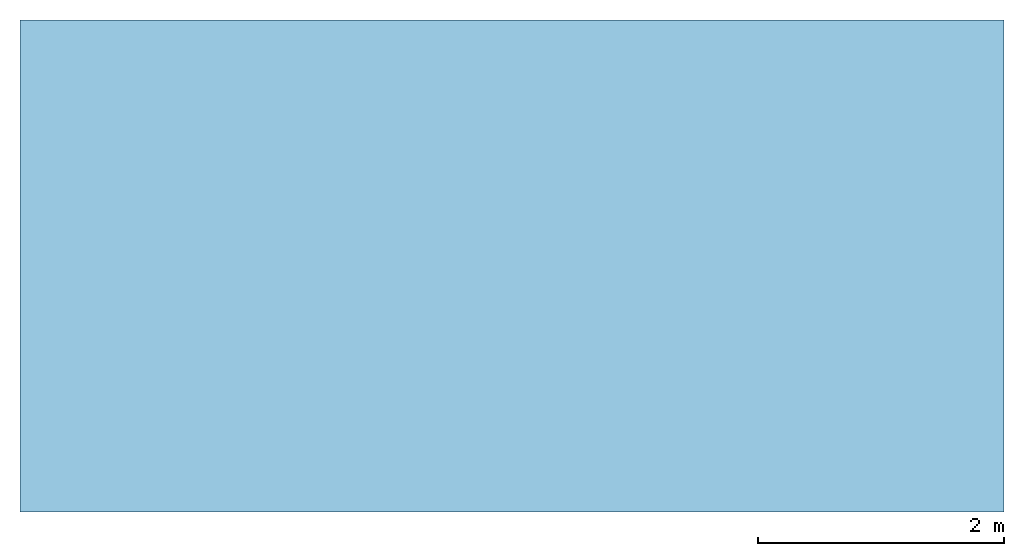
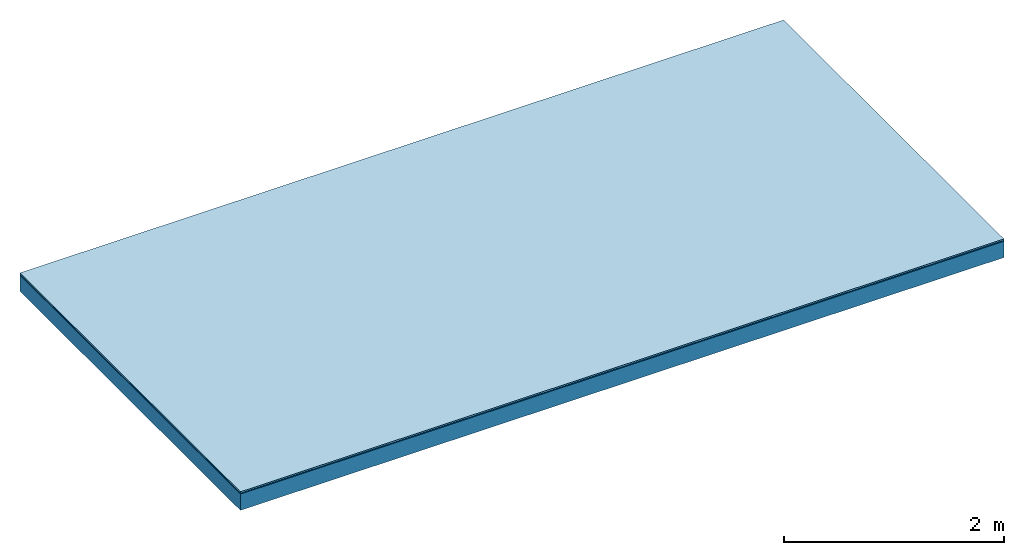
# One storey: 3 plates, 1 member, 1 element without a shape of its own.
"""IFC4 building model written with IfcOpenShell, lengths in metres."""

from ifc_helpers import new_model, si_unit, derived_unit, direction, frame, frame_2d, origin, origin_with_axes, place, context, project, spatial, rectangle, extrude, material, layer, layer_set, type_object, element, aggregate, save


model = new_model("IFC4")

# Units and contexts
plan_context = context("Plan", 3, precision=1e-05, world=origin(), true_north=direction((0.0, 1.0)))
model_context = context("Model", 3, precision=1e-05, world=origin(), true_north=direction((0.0, 1.0)))
ifc_project = project(units=[si_unit("LENGTHUNIT", "METRE"), derived_unit("SOUNDPRESSUREUNIT", [(si_unit("PRESSUREUNIT", "PASCAL", prefix="MICRO"), 0)]), si_unit("ENERGYUNIT", "JOULE", prefix="MEGA"), si_unit("MASSUNIT", "GRAM", prefix="KILO"), derived_unit("THERMALTRANSMITTANCEUNIT", [(si_unit("POWERUNIT", "WATT"), 1), (si_unit("AREAUNIT", "SQUARE_METRE"), -1), (si_unit("THERMODYNAMICTEMPERATUREUNIT", "KELVIN"), -1)]), derived_unit("AREADENSITYUNIT", [(si_unit("MASSUNIT", "GRAM", prefix="KILO"), 1), (si_unit("AREAUNIT", "SQUARE_METRE"), -1)]), derived_unit("USERDEFINED", [(si_unit("ENERGYUNIT", "JOULE", prefix="MEGA"), 1), (si_unit("AREAUNIT", "SQUARE_METRE"), -1)])], contexts=[plan_context, model_context])

# Site, building, storey
site = spatial("IfcSite", under=ifc_project)
building_placement = place(None, origin())
building = spatial("IfcBuilding", under=site, at=building_placement)
storey_placement = place(building_placement, origin())
storey = spatial("IfcBuildingStorey", under=building, at=storey_placement)

# Slab, member, plates
ifc_material_1 = material(Category="11.013")
ifc_layer_1 = layer(ifc_material_1, 0.015, Name="Flooring")
ifc_material_2 = material(Name="Wood fiber generic product", Category="10.009")
ifc_layer_2 = layer(ifc_material_2, 0.01, Name="Impact sound insulation")
ifc_material_3 = material(Name="protection", Category="09.007")
ifc_layer_3 = layer(ifc_material_3, 0.0005, Name="Sub-floor")
ifc_material_4 = material(Name="no composite action")
ifc_layer_4 = layer(ifc_material_4, 0.0, Name="Bond")
ifc_layer_5 = layer(None, 0.18, Name="Supporting structure")
ifc_layer_set = layer_set([ifc_layer_1, ifc_layer_2, ifc_layer_3, ifc_layer_4, ifc_layer_5])
slab_type = type_object("IfcSlabType", Name="A2009", PredefinedType="NOTDEFINED", material=ifc_layer_set)
slab_placement = place(None, frame((0.0, 0.0, 0.0), z_axis=(0.0, 0.0, -1.0), x_axis=(1.0, 0.0, 0.0)))
slab = element("IfcSlab", 1, at=slab_placement, inside=storey, type_object=slab_type, material=ifc_layer_set, Name="Slab #1")
ifc_material_5 = material(Name="Solid timber panel")
member_placement = place(slab_placement, origin())
member = element("IfcMember", 2, at=member_placement, material=ifc_material_5, Name="Supporting structure", context=plan_context, shape_type="SweptSolid", body=[
    extrude(rectangle(XDim=1.0, YDim=0.18, at=frame_2d((0.5, 0.09), x_axis=(1.0, 0.0))), frame((0.0, 4.0, 0.0255), z_axis=(0.0, -1.0, 0.0), x_axis=(1.0, 0.0, 0.0)), (0.0, 0.0, 1.0), 4.0),
    extrude(rectangle(XDim=1.0, YDim=0.18, at=frame_2d((0.5, 0.09), x_axis=(1.0, 0.0))), frame((1.0, 4.0, 0.0255), z_axis=(0.0, -1.0, 0.0), x_axis=(1.0, 0.0, 0.0)), (0.0, 0.0, 1.0), 4.0),
    extrude(rectangle(XDim=1.0, YDim=0.18, at=frame_2d((0.5, 0.09), x_axis=(1.0, 0.0))), frame((2.0, 4.0, 0.0255), z_axis=(0.0, -1.0, 0.0), x_axis=(1.0, 0.0, 0.0)), (0.0, 0.0, 1.0), 4.0),
    extrude(rectangle(XDim=1.0, YDim=0.18, at=frame_2d((0.5, 0.09), x_axis=(1.0, 0.0))), frame((3.0, 4.0, 0.0255), z_axis=(0.0, -1.0, 0.0), x_axis=(1.0, 0.0, 0.0)), (0.0, 0.0, 1.0), 4.0),
    extrude(rectangle(XDim=1.0, YDim=0.18, at=frame_2d((0.5, 0.09), x_axis=(1.0, 0.0))), frame((4.0, 4.0, 0.0255), z_axis=(0.0, -1.0, 0.0), x_axis=(1.0, 0.0, 0.0)), (0.0, 0.0, 1.0), 4.0),
    extrude(rectangle(XDim=1.0, YDim=0.18, at=frame_2d((0.5, 0.09), x_axis=(1.0, 0.0))), frame((5.0, 4.0, 0.0255), z_axis=(0.0, -1.0, 0.0), x_axis=(1.0, 0.0, 0.0)), (0.0, 0.0, 1.0), 4.0),
    extrude(rectangle(XDim=1.0, YDim=0.18, at=frame_2d((0.5, 0.09), x_axis=(1.0, 0.0))), frame((6.0, 4.0, 0.0255), z_axis=(0.0, -1.0, 0.0), x_axis=(1.0, 0.0, 0.0)), (0.0, 0.0, 1.0), 4.0),
    extrude(rectangle(XDim=1.0, YDim=0.18, at=frame_2d((0.5, 0.09), x_axis=(1.0, 0.0))), frame((7.0, 4.0, 0.0255), z_axis=(0.0, -1.0, 0.0), x_axis=(1.0, 0.0, 0.0)), (0.0, 0.0, 1.0), 4.0),
])
plate_1_placement = place(slab_placement, origin())
plate_1 = element("IfcPlate", 3, at=plate_1_placement, material=ifc_material_1, Name="Flooring", context=plan_context, shape_type="SweptSolid", body=[
    extrude(rectangle(XDim=8.0, YDim=4.0, at=frame_2d((4.0, 2.0), x_axis=(1.0, 0.0))), origin_with_axes(), (0.0, 0.0, 1.0), 0.015),
])
plate_2_placement = place(slab_placement, origin())
plate_2 = element("IfcPlate", 4, at=plate_2_placement, material=ifc_material_2, Name="Impact sound insulation", context=plan_context, shape_type="SweptSolid", body=[
    extrude(rectangle(XDim=8.0, YDim=4.0, at=frame_2d((4.0, 2.0), x_axis=(1.0, 0.0))), frame((0.0, 0.0, 0.015), z_axis=(0.0, 0.0, 1.0), x_axis=(1.0, 0.0, 0.0)), (0.0, 0.0, 1.0), 0.01),
])
plate_3_placement = place(slab_placement, origin())
plate_3 = element("IfcPlate", 5, at=plate_3_placement, material=ifc_material_3, Name="Sub-floor", context=plan_context, shape_type="SweptSolid", body=[
    extrude(rectangle(XDim=8.0, YDim=4.0, at=frame_2d((4.0, 2.0), x_axis=(1.0, 0.0))), frame((0.0, 0.0, 0.025), z_axis=(0.0, 0.0, 1.0), x_axis=(1.0, 0.0, 0.0)), (0.0, 0.0, 1.0), 0.0005),
])
aggregate(slab, [plate_1, plate_2, plate_3, member])

save(model, "model.ifc")
